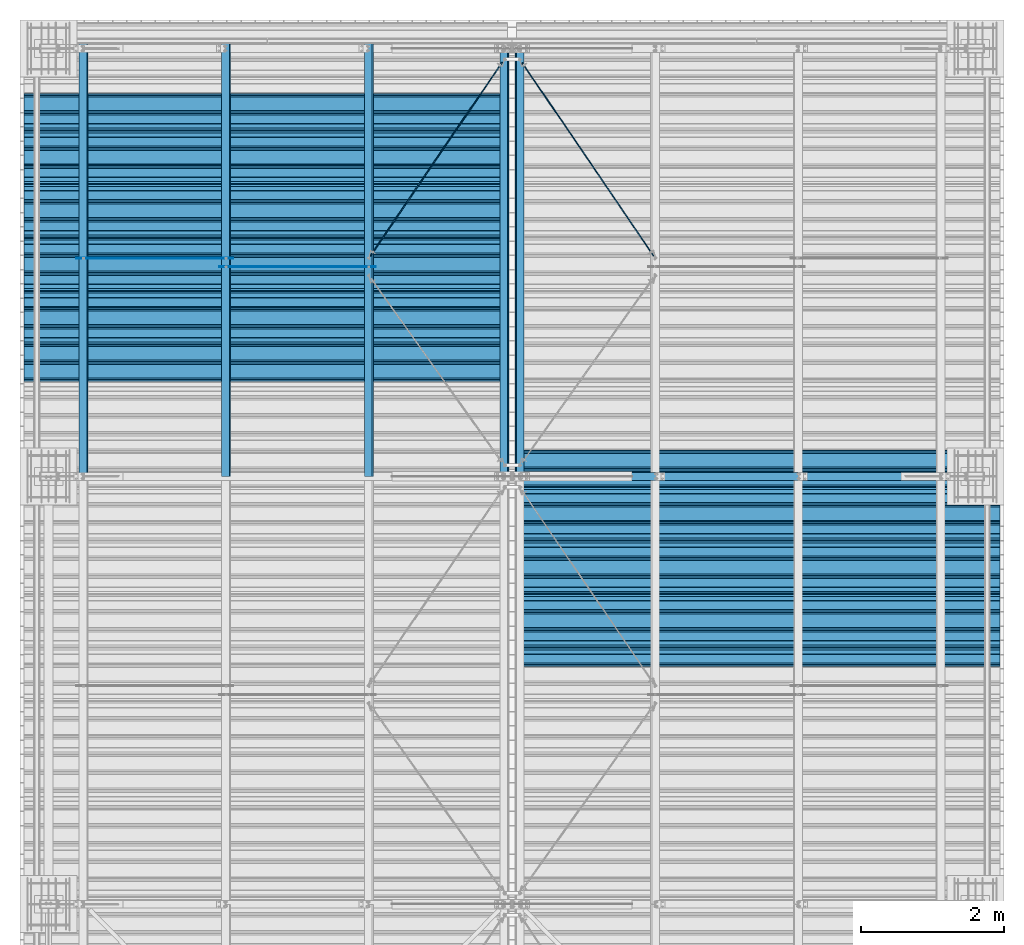
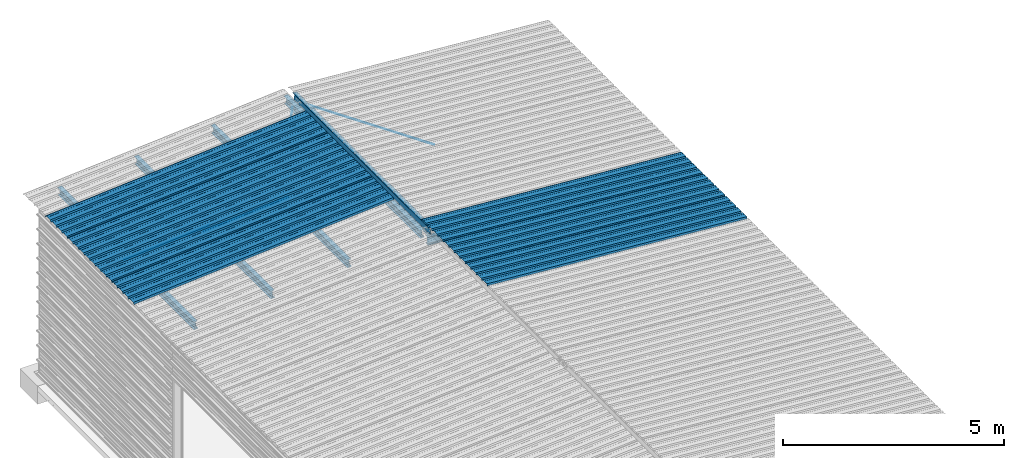
# One storey, part 17 of 70: 17 beams, 17 elements without a shape of their own.
"""IFC2X3 building model written with IfcOpenShell, lengths in millimetres."""

import ifcopenshell
import ifcopenshell.guid

model = None  # the IFC model being written
_history = None  # IfcOwnerHistory: only IFC2X3 demands one
_inside = {}  # id of a spatial element -> (the spatial element, [elements in it])
_under = {}  # id of a project, library or spatial element -> (it, [spatial elements below it])
_declared = {}  # id of a project -> (the project, [libraries it declares])
_typed = {}  # id of a type object -> (the type object, [elements of that type])
_made_of = {}  # id of a material, layer set ... -> (it, [elements and type objects made of it])


def new_model(schema):
    """Start an empty IFC model of exactly this schema.

    Asked for "IFC4X3", IfcOpenShell would pick the latest addendum, in which some entities
    have other attributes; the version numbers below select the first issue.
    IFC2X3 requires an IfcOwnerHistory on every rooted entity: one is made here for all.
    """
    global model, _history
    if schema == "IFC4X3":
        model = ifcopenshell.file(schema_version=(4, 3, 0, 0))
    else:
        model = ifcopenshell.file(schema=schema)
    _inside.clear()
    _under.clear()
    _declared.clear()
    _typed.clear()
    _made_of.clear()
    _history = None
    if model.schema == "IFC2X3":
        org = make("IfcOrganization", Name="unknown")
        user = make(
            "IfcPersonAndOrganization",
            ThePerson=make("IfcPerson", FamilyName="unknown"),
            TheOrganization=org,
        )
        app = make(
            "IfcApplication",
            ApplicationDeveloper=org,
            Version="unknown",
            ApplicationFullName="unknown",
            ApplicationIdentifier="unknown",
        )
        _history = make(
            "IfcOwnerHistory",
            OwningUser=user,
            OwningApplication=app,
            ChangeAction="ADDED",
            CreationDate=0,
        )
    return model


def make(cls, **values):
    """One entity of the class cls with the attributes given. An attribute that is None is left unset."""
    return model.create_entity(
        cls, **{name: value for name, value in values.items() if value is not None}
    )


def rooted(cls, **values):
    """An entity with a GlobalId (a new one), such as an element, a storey or a relation."""
    return make(cls, GlobalId=ifcopenshell.guid.new(), OwnerHistory=_history, **values)


def si_unit(unit_type, name, prefix=None):
    """IfcSIUnit, for example si_unit("LENGTHUNIT", "METRE", prefix="MILLI")."""
    return make("IfcSIUnit", UnitType=unit_type, Prefix=prefix, Name=name)


def assignment(units):
    """IfcUnitAssignment: the units of a project."""
    return None if units is None else make("IfcUnitAssignment", Units=units)


def point(xyz):
    """IfcCartesianPoint."""
    return None if xyz is None else make("IfcCartesianPoint", Coordinates=xyz)


def direction(xyz):
    """IfcDirection."""
    return None if xyz is None else make("IfcDirection", DirectionRatios=xyz)


def frame(location, z_axis=None, x_axis=None):
    """IfcAxis2Placement3D, a coordinate frame: its origin and axes. An axis left out is left unset."""
    return make(
        "IfcAxis2Placement3D",
        Location=point(location),
        Axis=direction(z_axis),
        RefDirection=direction(x_axis),
    )


def frame_2d(location, x_axis=None):
    """IfcAxis2Placement2D, a coordinate frame in the plane: its origin and x axis."""
    return make(
        "IfcAxis2Placement2D", Location=point(location), RefDirection=direction(x_axis)
    )


def origin_with_axes():
    """The frame at (0, 0, 0) with the z axis (0, 0, 1) and the x axis (1, 0, 0) written out."""
    return frame((0.0, 0.0, 0.0), z_axis=(0.0, 0.0, 1.0), x_axis=(1.0, 0.0, 0.0))


def origin_2d_with_axis():
    """The frame at (0, 0) in the plane with the x axis (1, 0) written out."""
    return frame_2d((0.0, 0.0), x_axis=(1.0, 0.0))


def place(relative_to, where):
    """IfcLocalPlacement: puts the frame where relative to a parent placement (None: the world)."""
    return make(
        "IfcLocalPlacement", PlacementRelTo=relative_to, RelativePlacement=where
    )


def context(
    kind, dimensions, precision=None, world=None, true_north=None, identifier=None
):
    """IfcGeometricRepresentationContext, for example the 3D "Model" context."""
    return make(
        "IfcGeometricRepresentationContext",
        ContextIdentifier=identifier,
        ContextType=kind,
        CoordinateSpaceDimension=dimensions,
        Precision=precision,
        WorldCoordinateSystem=world,
        TrueNorth=true_north,
    )


def subcontext(parent, identifier, kind, view, scale=None):
    """IfcGeometricRepresentationSubContext, for example "Body" below "Model"."""
    return make(
        "IfcGeometricRepresentationSubContext",
        ContextIdentifier=identifier,
        ContextType=kind,
        ParentContext=parent,
        TargetScale=scale,
        TargetView=view,
    )


def project(units=None, contexts=None):
    """IfcProject with its units and contexts."""
    return rooted(
        "IfcProject",
        Name="project",
        RepresentationContexts=contexts,
        UnitsInContext=assignment(units),
    )


def spatial(cls, under=None, at=None, **own):
    """A site, building, storey or space (cls), placed at a placement, below another one or the project."""
    s = rooted(cls, ObjectPlacement=at, **own)
    if under is not None:
        _under.setdefault(under.id(), (under, []))[1].append(s)
    return s


def polyline(points):
    """IfcPolyline through the points."""
    return make("IfcPolyline", Points=[point(p) for p in points])


def profile(cls, at=None, kind="AREA", **sizes):
    """A parametric profile (cls). Its sizes go by their IFC names, for example OverallWidth=200.0."""
    return make(cls, ProfileType=kind, Position=at, **sizes)


def circle(**sizes):
    """IfcCircleProfileDef."""
    return profile("IfcCircleProfileDef", **sizes)


def i_section(**sizes):
    """IfcIShapeProfileDef."""
    return profile("IfcIShapeProfileDef", **sizes)


def outline(outer, holes=None, kind="AREA"):
    """IfcArbitraryClosedProfileDef: a profile drawn as a closed curve; with holes, ...WithVoids."""
    if holes is None:
        return make("IfcArbitraryClosedProfileDef", ProfileType=kind, OuterCurve=outer)
    return make(
        "IfcArbitraryProfileDefWithVoids",
        ProfileType=kind,
        OuterCurve=outer,
        InnerCurves=holes,
    )


def extrude(swept, where, along, depth):
    """IfcExtrudedAreaSolid: the profile swept, set in the frame where, extruded along a direction by depth."""
    return make(
        "IfcExtrudedAreaSolid",
        SweptArea=swept,
        Position=where,
        ExtrudedDirection=direction(along),
        Depth=depth,
    )


def clip(a, b, op="DIFFERENCE"):
    """IfcBooleanClippingResult: the solid a cut by the half space b."""
    return make(
        "IfcBooleanClippingResult", Operator=op, FirstOperand=a, SecondOperand=b
    )


def halfspace(plane, agree):
    """IfcHalfSpaceSolid: all space on one side of the plane z = 0 of the frame plane."""
    return make(
        "IfcHalfSpaceSolid",
        BaseSurface=make("IfcPlane", Position=plane),
        AgreementFlag=agree,
    )


def shape(context_of_items, identifier, shape_type, items):
    """IfcShapeRepresentation: the items that make up one representation, for example the "Body"."""
    return make(
        "IfcShapeRepresentation",
        ContextOfItems=context_of_items,
        RepresentationIdentifier=identifier,
        RepresentationType=shape_type,
        Items=items,
    )


def material(Name=None, Category=None):
    """IfcMaterial."""
    return make("IfcMaterial", Name=Name, Category=Category)


def made_of(thing, what):
    """Note that an element or type object is made of a material, layer set ...; save() writes the relation."""
    if what is not None:
        _made_of.setdefault(what.id(), (what, []))[1].append(thing)
    return thing


def type_object(cls, material=None, **own):
    """A type object (cls), such as IfcWallType, which elements share."""
    return made_of(rooted(cls, **own), material)


def element(
    cls,
    number,
    at=None,
    inside=None,
    cuts=None,
    type_object=None,
    material=None,
    context=None,
    identifier="Body",
    shape_type=None,
    held_by="IfcProductDefinitionShape",
    body=None,
    shapes=None,
    **own,
):
    """One element of the class cls, such as IfcWall. Its Tag is "e" and its number.

    at: its placement. inside: the storey or other place that contains it. cuts: it is an
    opening in that element (IfcRelVoidsElement). A single representation is given by context,
    identifier, shape_type and body (its items); several are given by shapes. held_by: the class
    of the entity that holds the representations. save() writes the other relations.
    """
    e = rooted(cls, Tag="e%d" % number, ObjectPlacement=at, **own)
    if body is not None:
        shapes = [shape(context, identifier, shape_type, body)]
    if shapes is not None:
        e.Representation = make(held_by, Representations=shapes)
    if inside is not None:
        _inside.setdefault(inside.id(), (inside, []))[1].append(e)
    if cuts is not None:
        rooted(
            "IfcRelVoidsElement", RelatingBuildingElement=cuts, RelatedOpeningElement=e
        )
    if type_object is not None:
        _typed.setdefault(type_object.id(), (type_object, []))[1].append(e)
    return made_of(e, material)


def aggregate(whole, parts):
    """IfcRelAggregates: a whole, such as a stair, and the parts it consists of."""
    return rooted("IfcRelAggregates", RelatingObject=whole, RelatedObjects=parts)


def save(model, path):
    """Write the relations noted so far, then the file.

    IfcRelAggregates (storeys below a building ...), IfcRelContainedInSpatialStructure (elements
    in a storey), IfcRelDefinesByType, IfcRelAssociatesMaterial and IfcRelDeclares: one each for
    every whole, place, type object, material and project.
    """
    for whole, parts in _under.values():
        aggregate(whole, parts)
    for where, things in _inside.values():
        rooted(
            "IfcRelContainedInSpatialStructure",
            RelatedElements=things,
            RelatingStructure=where,
        )
    for kind, things in _typed.values():
        rooted("IfcRelDefinesByType", RelatedObjects=things, RelatingType=kind)
    for what, things in _made_of.values():
        rooted("IfcRelAssociatesMaterial", RelatedObjects=things, RelatingMaterial=what)
    for by, libraries in _declared.values():
        rooted("IfcRelDeclares", RelatingContext=by, RelatedDefinitions=libraries)
    model.write(path)


model = new_model("IFC2X3")

# Units and contexts
model_context = context("Model", 3, precision=1e-05, world=origin_with_axes())
body_context = subcontext(model_context, "Body", "Model", "MODEL_VIEW")
ifc_project = project(units=[si_unit("LENGTHUNIT", "METRE", prefix="MILLI"), si_unit("AREAUNIT", "SQUARE_METRE"), si_unit("VOLUMEUNIT", "CUBIC_METRE"), si_unit("MASSUNIT", "GRAM", prefix="KILO"), si_unit("TIMEUNIT", "SECOND"), si_unit("PLANEANGLEUNIT", "RADIAN"), si_unit("SOLIDANGLEUNIT", "STERADIAN"), si_unit("THERMODYNAMICTEMPERATUREUNIT", "DEGREE_CELSIUS"), si_unit("LUMINOUSINTENSITYUNIT", "LUMEN")], contexts=[model_context])

# Site, building, storey
site_placement = place(None, origin_with_axes())
site = spatial("IfcSite", under=ifc_project, at=site_placement, CompositionType="ELEMENT")
building_placement = place(site_placement, origin_with_axes())
building = spatial("IfcBuilding", under=site, at=building_placement, Name="Undefined", CompositionType="ELEMENT")
storey_placement = place(building_placement, origin_with_axes())
storey = spatial("IfcBuildingStorey", under=building, at=storey_placement, Name="Undefined", CompositionType="ELEMENT", Elevation=0.0)

# Assembly, beam
assembly_1_placement = place(storey_placement, origin_with_axes())
assembly_1 = element("IfcElementAssembly", 1, at=assembly_1_placement, inside=storey, Name="Steel Assembly", AssemblyPlace="NOTDEFINED", PredefinedType="RIGID_FRAME")
ifc_material = material(Name="STEEL/S235JR")
beam_type_1 = type_object("IfcBeamType", Name="4.40", PredefinedType="NOTDEFINED")
beam_1_placement = place(assembly_1_placement, frame((6563.60751131961, 15850.0000000002, 5336.31760454395), z_axis=(-0.0766964990376782, 0.0, -0.997054485489817), x_axis=(0.997054485489817, 0.0, -0.0766964990376783)))
beam_1 = element("IfcBeam", 2, at=beam_1_placement, type_object=beam_type_1, material=ifc_material, ObjectType="4.40", context=body_context, shape_type="SweptSolid", body=[
    extrude(outline(polyline([(509.415161132813, 19.5000000011705), (490.584838867188, 19.5000000011705), (468.084838867188, -20.4999999988113), (406.585784912109, -20.4999999988113), (404.585784912109, -18.4999999988122), (345.414215087891, -18.4999999988122), (343.414215087891, -20.4999999988113), (281.915161132813, -20.4999999988113), (259.415161132813, 19.5000000011705), (240.584854125977, 19.5000000011705), (218.084854125977, -20.4999999988113), (156.585784912109, -20.4999999988113), (154.585784912109, -18.4999999988122), (95.4142150878906, -18.4999999988122), (93.4142150878906, -20.4999999988113), (31.9151515960693, -20.4999999988113), (9.41515254974365, 19.5000000011705), (-9.41515254974365, 19.5000000011705), (-31.9151515960693, -20.4999999988113), (-93.4142150878906, -20.4999999988113), (-95.4142150878906, -18.4999999988122), (-154.585784912109, -18.4999999988122), (-156.585784912109, -20.4999999988113), (-218.084854125977, -20.4999999988113), (-240.584854125977, 19.5000000011705), (-259.415161132813, 19.5000000011705), (-281.915161132813, -20.4999999988113), (-343.414215087891, -20.4999999988113), (-345.414215087891, -18.4999999988122), (-404.585784912109, -18.4999999988122), (-406.585784912109, -20.4999999988113), (-468.084838867188, -20.4999999988113), (-490.584838867188, 19.5000000011705), (-509.415161132813, 19.5000000011705), (-516.482360839844, 6.9361057293263), (-517.353942871094, 7.42636680720625), (-510.0, 20.5000000011705), (-490.0, 20.5000000011705), (-467.5, -19.4999999988122), (-407.0, -19.4999999988122), (-405.0, -17.4999999988131), (-345.0, -17.4999999988131), (-343.0, -19.4999999988122), (-282.5, -19.4999999988122), (-260.0, 20.5000000011705), (-240.0, 20.5000000011705), (-217.5, -19.4999999988122), (-157.0, -19.4999999988122), (-155.0, -17.4999999988131), (-95.0, -17.4999999988131), (-93.0, -19.4999999988122), (-32.5, -19.4999999988122), (-10.0, 20.5000000011705), (10.0, 20.5000000011705), (32.5, -19.4999999988122), (93.0, -19.4999999988122), (95.0, -17.4999999988131), (155.0, -17.4999999988131), (157.0, -19.4999999988122), (217.5, -19.4999999988122), (240.0, 20.5000000011705), (260.0, 20.5000000011705), (282.5, -19.4999999988122), (343.0, -19.4999999988122), (345.0, -17.4999999988131), (405.0, -17.4999999988131), (407.0, -19.4999999988122), (467.5, -19.4999999988122), (490.0, 20.5000000011705), (510.0, 20.5000000011705), (517.353942871094, 7.42636680720625), (516.482360839844, 6.9361057293263), (509.415161132813, 19.5000000011705)])), frame((6799.99999999733, 2.8421709430404e-14, 0.0), z_axis=(-1.0, 0.0, 0.0), x_axis=(0.0, -1.0, 0.0)), (0.0, 0.0, 1.0), 6800.0),
])
aggregate(assembly_1, [beam_1])

assembly_2_placement = place(storey_placement, origin_with_axes())
assembly_2 = element("IfcElementAssembly", 3, at=assembly_2_placement, inside=storey, Name="Steel Assembly", AssemblyPlace="NOTDEFINED", PredefinedType="RIGID_FRAME")
beam_2_placement = place(assembly_2_placement, frame((6563.60751131961, 16850.0000000002, 5336.31760454398), z_axis=(-0.0766964990376782, 0.0, -0.997054485489817), x_axis=(0.997054485489817, 0.0, -0.0766964990376783)))
beam_2 = element("IfcBeam", 4, at=beam_2_placement, type_object=beam_type_1, material=ifc_material, ObjectType="4.40", context=body_context, shape_type="SweptSolid", body=[
    extrude(outline(polyline([(509.415161132813, 19.5000000011705), (490.584838867188, 19.5000000011705), (468.084838867188, -20.4999999988113), (406.585784912109, -20.4999999988113), (404.585784912109, -18.4999999988122), (345.414215087891, -18.4999999988122), (343.414215087891, -20.4999999988113), (281.915161132813, -20.4999999988113), (259.415161132813, 19.5000000011705), (240.584854125977, 19.5000000011705), (218.084854125977, -20.4999999988113), (156.585784912109, -20.4999999988113), (154.585784912109, -18.4999999988122), (95.4142150878906, -18.4999999988122), (93.4142150878906, -20.4999999988113), (31.9151515960693, -20.4999999988113), (9.41515254974365, 19.5000000011705), (-9.41515254974365, 19.5000000011705), (-31.9151515960693, -20.4999999988113), (-93.4142150878906, -20.4999999988113), (-95.4142150878906, -18.4999999988122), (-154.585784912109, -18.4999999988122), (-156.585784912109, -20.4999999988113), (-218.084854125977, -20.4999999988113), (-240.584854125977, 19.5000000011705), (-259.415161132813, 19.5000000011705), (-281.915161132813, -20.4999999988113), (-343.414215087891, -20.4999999988113), (-345.414215087891, -18.4999999988122), (-404.585784912109, -18.4999999988122), (-406.585784912109, -20.4999999988113), (-468.084838867188, -20.4999999988113), (-490.584838867188, 19.5000000011705), (-509.415161132813, 19.5000000011705), (-516.482360839844, 6.9361057293263), (-517.353942871094, 7.42636680720625), (-510.0, 20.5000000011705), (-490.0, 20.5000000011705), (-467.5, -19.4999999988122), (-407.0, -19.4999999988122), (-405.0, -17.4999999988131), (-345.0, -17.4999999988131), (-343.0, -19.4999999988122), (-282.5, -19.4999999988122), (-260.0, 20.5000000011705), (-240.0, 20.5000000011705), (-217.5, -19.4999999988122), (-157.0, -19.4999999988122), (-155.0, -17.4999999988131), (-95.0, -17.4999999988131), (-93.0, -19.4999999988122), (-32.5, -19.4999999988122), (-10.0, 20.5000000011705), (10.0, 20.5000000011705), (32.5, -19.4999999988122), (93.0, -19.4999999988122), (95.0, -17.4999999988131), (155.0, -17.4999999988131), (157.0, -19.4999999988122), (217.5, -19.4999999988122), (240.0, 20.5000000011705), (260.0, 20.5000000011705), (282.5, -19.4999999988122), (343.0, -19.4999999988122), (345.0, -17.4999999988131), (405.0, -17.4999999988131), (407.0, -19.4999999988122), (467.5, -19.4999999988122), (490.0, 20.5000000011705), (510.0, 20.5000000011705), (517.353942871094, 7.42636680720625), (516.482360839844, 6.9361057293263), (509.415161132813, 19.5000000011705)])), frame((6799.99999999733, 2.8421709430404e-14, 0.0), z_axis=(-1.0, 0.0, 0.0), x_axis=(0.0, -1.0, 0.0)), (0.0, 0.0, 1.0), 6800.0),
])
aggregate(assembly_2, [beam_2])

assembly_3_placement = place(storey_placement, origin_with_axes())
assembly_3 = element("IfcElementAssembly", 5, at=assembly_3_placement, inside=storey, Name="Steel Assembly", AssemblyPlace="NOTDEFINED", PredefinedType="RIGID_FRAME")
beam_3_placement = place(assembly_3_placement, frame((6563.60751131961, 17850.0000000002, 5336.31760454401), z_axis=(-0.0766964990376782, 0.0, -0.997054485489817), x_axis=(0.997054485489817, 0.0, -0.0766964990376783)))
beam_3 = element("IfcBeam", 6, at=beam_3_placement, type_object=beam_type_1, material=ifc_material, ObjectType="4.40", context=body_context, shape_type="SweptSolid", body=[
    extrude(outline(polyline([(509.415161132813, 19.5000000011705), (490.584838867188, 19.5000000011705), (468.084838867188, -20.4999999988113), (406.585784912109, -20.4999999988113), (404.585784912109, -18.4999999988122), (345.414215087891, -18.4999999988122), (343.414215087891, -20.4999999988113), (281.915161132813, -20.4999999988113), (259.415161132813, 19.5000000011705), (240.584854125977, 19.5000000011705), (218.084854125977, -20.4999999988113), (156.585784912109, -20.4999999988113), (154.585784912109, -18.4999999988122), (95.4142150878906, -18.4999999988122), (93.4142150878906, -20.4999999988113), (31.9151515960693, -20.4999999988113), (9.41515254974365, 19.5000000011705), (-9.41515254974365, 19.5000000011705), (-31.9151515960693, -20.4999999988113), (-93.4142150878906, -20.4999999988113), (-95.4142150878906, -18.4999999988122), (-154.585784912109, -18.4999999988122), (-156.585784912109, -20.4999999988113), (-218.084854125977, -20.4999999988113), (-240.584854125977, 19.5000000011705), (-259.415161132813, 19.5000000011705), (-281.915161132813, -20.4999999988113), (-343.414215087891, -20.4999999988113), (-345.414215087891, -18.4999999988122), (-404.585784912109, -18.4999999988122), (-406.585784912109, -20.4999999988113), (-468.084838867188, -20.4999999988113), (-490.584838867188, 19.5000000011705), (-509.415161132813, 19.5000000011705), (-516.482360839844, 6.9361057293263), (-517.353942871094, 7.42636680720625), (-510.0, 20.5000000011705), (-490.0, 20.5000000011705), (-467.5, -19.4999999988122), (-407.0, -19.4999999988122), (-405.0, -17.4999999988131), (-345.0, -17.4999999988131), (-343.0, -19.4999999988122), (-282.5, -19.4999999988122), (-260.0, 20.5000000011705), (-240.0, 20.5000000011705), (-217.5, -19.4999999988122), (-157.0, -19.4999999988122), (-155.0, -17.4999999988131), (-95.0, -17.4999999988131), (-93.0, -19.4999999988122), (-32.5, -19.4999999988122), (-10.0, 20.5000000011705), (10.0, 20.5000000011705), (32.5, -19.4999999988122), (93.0, -19.4999999988122), (95.0, -17.4999999988131), (155.0, -17.4999999988131), (157.0, -19.4999999988122), (217.5, -19.4999999988122), (240.0, 20.5000000011705), (260.0, 20.5000000011705), (282.5, -19.4999999988122), (343.0, -19.4999999988122), (345.0, -17.4999999988131), (405.0, -17.4999999988131), (407.0, -19.4999999988122), (467.5, -19.4999999988122), (490.0, 20.5000000011705), (510.0, 20.5000000011705), (517.353942871094, 7.42636680720625), (516.482360839844, 6.9361057293263), (509.415161132813, 19.5000000011705)])), frame((6799.99999999733, 2.8421709430404e-14, 0.0), z_axis=(-1.0, 0.0, 0.0), x_axis=(0.0, -1.0, 0.0)), (0.0, 0.0, 1.0), 6800.0),
])
aggregate(assembly_3, [beam_3])

assembly_4_placement = place(storey_placement, origin_with_axes())
assembly_4 = element("IfcElementAssembly", 7, at=assembly_4_placement, inside=storey, Name="Steel Assembly", AssemblyPlace="NOTDEFINED", PredefinedType="RIGID_FRAME")
beam_4_placement = place(assembly_4_placement, frame((6436.39248868039, 19850.0, 5336.31760454388), z_axis=(0.0766964990376782, 0.0, -0.997054485489817), x_axis=(-0.997054485489818, 0.0, -0.0766964990376602)))
beam_4 = element("IfcBeam", 8, at=beam_4_placement, type_object=beam_type_1, material=ifc_material, ObjectType="4.40", context=body_context, shape_type="SweptSolid", body=[
    extrude(outline(polyline([(509.415161132813, 19.5000000011705), (490.584838867188, 19.5000000011705), (468.084838867188, -20.4999999988113), (406.585784912109, -20.4999999988113), (404.585784912109, -18.4999999988122), (345.414215087891, -18.4999999988122), (343.414215087891, -20.4999999988113), (281.915161132813, -20.4999999988113), (259.415161132813, 19.5000000011705), (240.584854125977, 19.5000000011705), (218.084854125977, -20.4999999988113), (156.585784912109, -20.4999999988113), (154.585784912109, -18.4999999988122), (95.4142150878906, -18.4999999988122), (93.4142150878906, -20.4999999988113), (31.9151515960693, -20.4999999988113), (9.41515254974365, 19.5000000011705), (-9.41515254974365, 19.5000000011705), (-31.9151515960693, -20.4999999988113), (-93.4142150878906, -20.4999999988113), (-95.4142150878906, -18.4999999988122), (-154.585784912109, -18.4999999988122), (-156.585784912109, -20.4999999988113), (-218.084854125977, -20.4999999988113), (-240.584854125977, 19.5000000011705), (-259.415161132813, 19.5000000011705), (-281.915161132813, -20.4999999988113), (-343.414215087891, -20.4999999988113), (-345.414215087891, -18.4999999988122), (-404.585784912109, -18.4999999988122), (-406.585784912109, -20.4999999988113), (-468.084838867188, -20.4999999988113), (-490.584838867188, 19.5000000011705), (-509.415161132813, 19.5000000011705), (-516.482360839844, 6.9361057293263), (-517.353942871094, 7.42636680720625), (-510.0, 20.5000000011705), (-490.0, 20.5000000011705), (-467.5, -19.4999999988122), (-407.0, -19.4999999988122), (-405.0, -17.4999999988131), (-345.0, -17.4999999988131), (-343.0, -19.4999999988122), (-282.5, -19.4999999988122), (-260.0, 20.5000000011705), (-240.0, 20.5000000011705), (-217.5, -19.4999999988122), (-157.0, -19.4999999988122), (-155.0, -17.4999999988131), (-95.0, -17.4999999988131), (-93.0, -19.4999999988122), (-32.5, -19.4999999988122), (-10.0, 20.5000000011705), (10.0, 20.5000000011705), (32.5, -19.4999999988122), (93.0, -19.4999999988122), (95.0, -17.4999999988131), (155.0, -17.4999999988131), (157.0, -19.4999999988122), (217.5, -19.4999999988122), (240.0, 20.5000000011705), (260.0, 20.5000000011705), (282.5, -19.4999999988122), (343.0, -19.4999999988122), (345.0, -17.4999999988131), (405.0, -17.4999999988131), (407.0, -19.4999999988122), (467.5, -19.4999999988122), (490.0, 20.5000000011705), (510.0, 20.5000000011705), (517.353942871094, 7.42636680720625), (516.482360839844, 6.9361057293263), (509.415161132813, 19.5000000011705)])), frame((6799.99999999733, 2.8421709430404e-14, 0.0), z_axis=(-1.0, 0.0, 0.0), x_axis=(0.0, -1.0, 0.0)), (0.0, 0.0, 1.0), 6800.0),
])
aggregate(assembly_4, [beam_4])

assembly_5_placement = place(storey_placement, origin_with_axes())
assembly_5 = element("IfcElementAssembly", 9, at=assembly_5_placement, inside=storey, Name="Steel Assembly", AssemblyPlace="NOTDEFINED", PredefinedType="RIGID_FRAME")
beam_5_placement = place(assembly_5_placement, frame((6436.39248868039, 20850.0, 5336.31760454388), z_axis=(0.0766964990376782, 0.0, -0.997054485489817), x_axis=(-0.997054485489818, 0.0, -0.0766964990376602)))
beam_5 = element("IfcBeam", 10, at=beam_5_placement, type_object=beam_type_1, material=ifc_material, ObjectType="4.40", context=body_context, shape_type="SweptSolid", body=[
    extrude(outline(polyline([(509.415161132813, 19.5000000011705), (490.584838867188, 19.5000000011705), (468.084838867188, -20.4999999988113), (406.585784912109, -20.4999999988113), (404.585784912109, -18.4999999988122), (345.414215087891, -18.4999999988122), (343.414215087891, -20.4999999988113), (281.915161132813, -20.4999999988113), (259.415161132813, 19.5000000011705), (240.584854125977, 19.5000000011705), (218.084854125977, -20.4999999988113), (156.585784912109, -20.4999999988113), (154.585784912109, -18.4999999988122), (95.4142150878906, -18.4999999988122), (93.4142150878906, -20.4999999988113), (31.9151515960693, -20.4999999988113), (9.41515254974365, 19.5000000011705), (-9.41515254974365, 19.5000000011705), (-31.9151515960693, -20.4999999988113), (-93.4142150878906, -20.4999999988113), (-95.4142150878906, -18.4999999988122), (-154.585784912109, -18.4999999988122), (-156.585784912109, -20.4999999988113), (-218.084854125977, -20.4999999988113), (-240.584854125977, 19.5000000011705), (-259.415161132813, 19.5000000011705), (-281.915161132813, -20.4999999988113), (-343.414215087891, -20.4999999988113), (-345.414215087891, -18.4999999988122), (-404.585784912109, -18.4999999988122), (-406.585784912109, -20.4999999988113), (-468.084838867188, -20.4999999988113), (-490.584838867188, 19.5000000011705), (-509.415161132813, 19.5000000011705), (-516.482360839844, 6.9361057293263), (-517.353942871094, 7.42636680720625), (-510.0, 20.5000000011705), (-490.0, 20.5000000011705), (-467.5, -19.4999999988122), (-407.0, -19.4999999988122), (-405.0, -17.4999999988131), (-345.0, -17.4999999988131), (-343.0, -19.4999999988122), (-282.5, -19.4999999988122), (-260.0, 20.5000000011705), (-240.0, 20.5000000011705), (-217.5, -19.4999999988122), (-157.0, -19.4999999988122), (-155.0, -17.4999999988131), (-95.0, -17.4999999988131), (-93.0, -19.4999999988122), (-32.5, -19.4999999988122), (-10.0, 20.5000000011705), (10.0, 20.5000000011705), (32.5, -19.4999999988122), (93.0, -19.4999999988122), (95.0, -17.4999999988131), (155.0, -17.4999999988131), (157.0, -19.4999999988122), (217.5, -19.4999999988122), (240.0, 20.5000000011705), (260.0, 20.5000000011705), (282.5, -19.4999999988122), (343.0, -19.4999999988122), (345.0, -17.4999999988131), (405.0, -17.4999999988131), (407.0, -19.4999999988122), (467.5, -19.4999999988122), (490.0, 20.5000000011705), (510.0, 20.5000000011705), (517.353942871094, 7.42636680720625), (516.482360839844, 6.9361057293263), (509.415161132813, 19.5000000011705)])), frame((6799.99999999733, 2.8421709430404e-14, 0.0), z_axis=(-1.0, 0.0, 0.0), x_axis=(0.0, -1.0, 0.0)), (0.0, 0.0, 1.0), 6800.0),
])
aggregate(assembly_5, [beam_5])

assembly_6_placement = place(storey_placement, origin_with_axes())
assembly_6 = element("IfcElementAssembly", 11, at=assembly_6_placement, inside=storey, Name="Steel Assembly", AssemblyPlace="NOTDEFINED", PredefinedType="RIGID_FRAME")
beam_6_placement = place(assembly_6_placement, frame((6436.39248868039, 21850.0, 5336.31760454388), z_axis=(0.0766964990376782, 0.0, -0.997054485489817), x_axis=(-0.997054485489818, 0.0, -0.0766964990376602)))
beam_6 = element("IfcBeam", 12, at=beam_6_placement, type_object=beam_type_1, material=ifc_material, ObjectType="4.40", context=body_context, shape_type="SweptSolid", body=[
    extrude(outline(polyline([(509.415161132813, 19.5000000011705), (490.584838867188, 19.5000000011705), (468.084838867188, -20.4999999988113), (406.585784912109, -20.4999999988113), (404.585784912109, -18.4999999988122), (345.414215087891, -18.4999999988122), (343.414215087891, -20.4999999988113), (281.915161132813, -20.4999999988113), (259.415161132813, 19.5000000011705), (240.584854125977, 19.5000000011705), (218.084854125977, -20.4999999988113), (156.585784912109, -20.4999999988113), (154.585784912109, -18.4999999988122), (95.4142150878906, -18.4999999988122), (93.4142150878906, -20.4999999988113), (31.9151515960693, -20.4999999988113), (9.41515254974365, 19.5000000011705), (-9.41515254974365, 19.5000000011705), (-31.9151515960693, -20.4999999988113), (-93.4142150878906, -20.4999999988113), (-95.4142150878906, -18.4999999988122), (-154.585784912109, -18.4999999988122), (-156.585784912109, -20.4999999988113), (-218.084854125977, -20.4999999988113), (-240.584854125977, 19.5000000011705), (-259.415161132813, 19.5000000011705), (-281.915161132813, -20.4999999988113), (-343.414215087891, -20.4999999988113), (-345.414215087891, -18.4999999988122), (-404.585784912109, -18.4999999988122), (-406.585784912109, -20.4999999988113), (-468.084838867188, -20.4999999988113), (-490.584838867188, 19.5000000011705), (-509.415161132813, 19.5000000011705), (-516.482360839844, 6.9361057293263), (-517.353942871094, 7.42636680720625), (-510.0, 20.5000000011705), (-490.0, 20.5000000011705), (-467.5, -19.4999999988122), (-407.0, -19.4999999988122), (-405.0, -17.4999999988131), (-345.0, -17.4999999988131), (-343.0, -19.4999999988122), (-282.5, -19.4999999988122), (-260.0, 20.5000000011705), (-240.0, 20.5000000011705), (-217.5, -19.4999999988122), (-157.0, -19.4999999988122), (-155.0, -17.4999999988131), (-95.0, -17.4999999988131), (-93.0, -19.4999999988122), (-32.5, -19.4999999988122), (-10.0, 20.5000000011705), (10.0, 20.5000000011705), (32.5, -19.4999999988122), (93.0, -19.4999999988122), (95.0, -17.4999999988131), (155.0, -17.4999999988131), (157.0, -19.4999999988122), (217.5, -19.4999999988122), (240.0, 20.5000000011705), (260.0, 20.5000000011705), (282.5, -19.4999999988122), (343.0, -19.4999999988122), (345.0, -17.4999999988131), (405.0, -17.4999999988131), (407.0, -19.4999999988122), (467.5, -19.4999999988122), (490.0, 20.5000000011705), (510.0, 20.5000000011705), (517.353942871094, 7.42636680720625), (516.482360839844, 6.9361057293263), (509.415161132813, 19.5000000011705)])), frame((6799.99999999733, 2.8421709430404e-14, 0.0), z_axis=(-1.0, 0.0, 0.0), x_axis=(0.0, -1.0, 0.0)), (0.0, 0.0, 1.0), 6800.0),
])
aggregate(assembly_6, [beam_6])

assembly_7_placement = place(storey_placement, origin_with_axes())
assembly_7 = element("IfcElementAssembly", 13, at=assembly_7_placement, inside=storey, Name="Steel Assembly", AssemblyPlace="NOTDEFINED", PredefinedType="RIGID_FRAME")
beam_7_placement = place(assembly_7_placement, frame((6436.39248868039, 22850.0, 5336.31760454388), z_axis=(0.0766964990376782, 0.0, -0.997054485489817), x_axis=(-0.997054485489818, 0.0, -0.0766964990376602)))
beam_7 = element("IfcBeam", 14, at=beam_7_placement, type_object=beam_type_1, material=ifc_material, ObjectType="4.40", context=body_context, shape_type="SweptSolid", body=[
    extrude(outline(polyline([(509.415161132813, 19.5000000011705), (490.584838867188, 19.5000000011705), (468.084838867188, -20.4999999988113), (406.585784912109, -20.4999999988113), (404.585784912109, -18.4999999988122), (345.414215087891, -18.4999999988122), (343.414215087891, -20.4999999988113), (281.915161132813, -20.4999999988113), (259.415161132813, 19.5000000011705), (240.584854125977, 19.5000000011705), (218.084854125977, -20.4999999988113), (156.585784912109, -20.4999999988113), (154.585784912109, -18.4999999988122), (95.4142150878906, -18.4999999988122), (93.4142150878906, -20.4999999988113), (31.9151515960693, -20.4999999988113), (9.41515254974365, 19.5000000011705), (-9.41515254974365, 19.5000000011705), (-31.9151515960693, -20.4999999988113), (-93.4142150878906, -20.4999999988113), (-95.4142150878906, -18.4999999988122), (-154.585784912109, -18.4999999988122), (-156.585784912109, -20.4999999988113), (-218.084854125977, -20.4999999988113), (-240.584854125977, 19.5000000011705), (-259.415161132813, 19.5000000011705), (-281.915161132813, -20.4999999988113), (-343.414215087891, -20.4999999988113), (-345.414215087891, -18.4999999988122), (-404.585784912109, -18.4999999988122), (-406.585784912109, -20.4999999988113), (-468.084838867188, -20.4999999988113), (-490.584838867188, 19.5000000011705), (-509.415161132813, 19.5000000011705), (-516.482360839844, 6.9361057293263), (-517.353942871094, 7.42636680720625), (-510.0, 20.5000000011705), (-490.0, 20.5000000011705), (-467.5, -19.4999999988122), (-407.0, -19.4999999988122), (-405.0, -17.4999999988131), (-345.0, -17.4999999988131), (-343.0, -19.4999999988122), (-282.5, -19.4999999988122), (-260.0, 20.5000000011705), (-240.0, 20.5000000011705), (-217.5, -19.4999999988122), (-157.0, -19.4999999988122), (-155.0, -17.4999999988131), (-95.0, -17.4999999988131), (-93.0, -19.4999999988122), (-32.5, -19.4999999988122), (-10.0, 20.5000000011705), (10.0, 20.5000000011705), (32.5, -19.4999999988122), (93.0, -19.4999999988122), (95.0, -17.4999999988131), (155.0, -17.4999999988131), (157.0, -19.4999999988122), (217.5, -19.4999999988122), (240.0, 20.5000000011705), (260.0, 20.5000000011705), (282.5, -19.4999999988122), (343.0, -19.4999999988122), (345.0, -17.4999999988131), (405.0, -17.4999999988131), (407.0, -19.4999999988122), (467.5, -19.4999999988122), (490.0, 20.5000000011705), (510.0, 20.5000000011705), (517.353942871094, 7.42636680720625), (516.482360839844, 6.9361057293263), (509.415161132813, 19.5000000011705)])), frame((6799.99999999733, 2.8421709430404e-14, 0.0), z_axis=(-1.0, 0.0, 0.0), x_axis=(0.0, -1.0, 0.0)), (0.0, 0.0, 1.0), 6800.0),
])
aggregate(assembly_7, [beam_7])

assembly_8_placement = place(storey_placement, origin_with_axes())
assembly_8 = element("IfcElementAssembly", 15, at=assembly_8_placement, inside=storey, Name="Steel Assembly", AssemblyPlace="NOTDEFINED", PredefinedType="RIGID_FRAME")
beam_type_2 = type_object("IfcBeamType", Name="D14", PredefinedType="NOTDEFINED")
beam_8_placement = place(assembly_8_placement, frame((6643.29022095678, 23798.8202310421, 5199.30263958542), z_axis=(-0.0766964990376782, 0.0, -0.997054485489817), x_axis=(0.562350226933823, -0.825766911902794, -0.0432577099948882)))
beam_8 = element("IfcBeam", 16, at=beam_8_placement, type_object=beam_type_2, material=ifc_material, Name="THREAD60MM", ObjectType="D14", context=body_context, shape_type="SweptSolid", body=[
    extrude(circle(Radius=7.0, at=origin_2d_with_axis()), frame((3276.46854148328, -3.44046790741365e-12, -2.27350675888422e-14), z_axis=(-1.0, 0.0, 0.0), x_axis=(0.0, -1.0, 0.0)), (0.0, 0.0, 1.0), 3276.47),
])
aggregate(assembly_8, [beam_8])

assembly_9_placement = place(storey_placement, origin_with_axes())
assembly_9 = element("IfcElementAssembly", 17, at=assembly_9_placement, inside=storey, Name="Steel Assembly", AssemblyPlace="NOTDEFINED", PredefinedType="RIGID_FRAME")
beam_9_placement = place(assembly_9_placement, frame((6360.89585869421, 23804.9671585294, 5199.62464571418), z_axis=(0.0766964990376782, 0.0, -0.997054485489817), x_axis=(-0.5623502269338, -0.825766911902807, -0.0432577099949295)))
beam_9 = element("IfcBeam", 18, at=beam_9_placement, type_object=beam_type_2, material=ifc_material, Name="THREAD60MM", ObjectType="D14", context=body_context, shape_type="SweptSolid", body=[
    extrude(circle(Radius=7.0, at=origin_2d_with_axis()), frame((3283.91244290157, 3.26911877658966e-12, -9.09494701772928e-13), z_axis=(-1.0, 0.0, 0.0), x_axis=(0.0, -1.0, 0.0)), (0.0, 0.0, 1.0), 3283.91),
])
aggregate(assembly_9, [beam_9])

assembly_10_placement = place(storey_placement, origin_with_axes())
assembly_10 = element("IfcElementAssembly", 19, at=assembly_10_placement, inside=storey, Name="Steel Assembly", AssemblyPlace="NOTDEFINED", PredefinedType="RIGID_FRAME")
beam_10_placement = place(assembly_10_placement, frame((2591.26883365322, 21060.0000000001, 4909.65333500212), z_axis=(0.0766964990376782, 0.0, -0.997054485489817), x_axis=(-0.997054485489818, 0.0, -0.0766964990376602)))
beam_10 = element("IfcBeam", 20, at=beam_10_placement, type_object=beam_type_2, material=ifc_material, Name="THREAD60MM", ObjectType="D14", context=body_context, shape_type="SweptSolid", body=[
    extrude(circle(Radius=7.0, at=origin_2d_with_axis()), frame((2205.90843239298, 9.09494701772928e-13, -9.40107830921147e-13), z_axis=(-1.0, 0.0, 0.0), x_axis=(0.0, -1.0, 0.0)), (0.0, 0.0, 1.0), 2205.91),
])
aggregate(assembly_10, [beam_10])

assembly_11_placement = place(storey_placement, origin_with_axes())
assembly_11 = element("IfcElementAssembly", 21, at=assembly_11_placement, inside=storey, Name="Steel Assembly", AssemblyPlace="NOTDEFINED", PredefinedType="RIGID_FRAME")
beam_11_placement = place(assembly_11_placement, frame((4591.26883365324, 20940.0000000001, 5063.49948915789), z_axis=(0.0766964990376782, 0.0, -0.997054485489817), x_axis=(-0.997054485489818, 0.0, -0.0766964990376602)))
beam_11 = element("IfcBeam", 22, at=beam_11_placement, type_object=beam_type_2, material=ifc_material, Name="THREAD60MM", ObjectType="D14", context=body_context, shape_type="SweptSolid", body=[
    extrude(circle(Radius=7.0, at=origin_2d_with_axis()), frame((2205.90843239298, 9.09494701772928e-13, -9.40107830921147e-13), z_axis=(-1.0, 0.0, 0.0), x_axis=(0.0, -1.0, 0.0)), (0.0, 0.0, 1.0), 2205.91),
])
aggregate(assembly_11, [beam_11])

assembly_12_placement = place(storey_placement, origin_with_axes())
assembly_12 = element("IfcElementAssembly", 23, at=assembly_12_placement, inside=storey, Name="Steel Assembly", AssemblyPlace="NOTDEFINED", PredefinedType="RIGID_FRAME")
beam_type_3 = type_object("IfcBeamType", Name="IPE220", PredefinedType="NOTDEFINED")
beam_12_placement = place(assembly_12_placement, frame((6608.43661485526, 18000.0, 5201.98368622298), z_axis=(0.0766964990376782, 0.0, 0.997054485489817), x_axis=(0.0, 1.0, 0.0)))
beam_12 = element("IfcBeam", 24, at=beam_12_placement, type_object=beam_type_3, material=ifc_material, ObjectType="IPE220", context=body_context, shape_type="Clipping", body=[
    clip(extrude(i_section(OverallWidth=110.0, OverallDepth=220.0, WebThickness=5.900000095, FlangeThickness=9.199999809, FilletRadius=12.0, at=origin_2d_with_axis()), frame((6150.0000000001, 0.0, 0.0), z_axis=(-1.0, 0.0, 0.0), x_axis=(0.0, -1.0, 0.0)), (0.0, 0.0, 1.0), 6145.0), halfspace(frame((4.99999999999636, 7.09405867382884e-11, -1.79170456249267e-10), z_axis=(1.0, 0.0, 0.0), x_axis=(0.0, -1.0, 0.0)), True)),
])
aggregate(assembly_12, [beam_12])

assembly_13_placement = place(storey_placement, origin_with_axes())
assembly_13 = element("IfcElementAssembly", 25, at=assembly_13_placement, inside=storey, Name="Steel Assembly", AssemblyPlace="NOTDEFINED", PredefinedType="RIGID_FRAME")
beam_13_placement = place(assembly_13_placement, frame((6391.56338514147, 24149.9999999999, 5201.98368623921), z_axis=(-0.0766964990376602, 0.0, 0.997054485489818), x_axis=(0.0, -1.0, 0.0)))
beam_13 = element("IfcBeam", 26, at=beam_13_placement, type_object=beam_type_3, material=ifc_material, ObjectType="IPE220", context=body_context, shape_type="Clipping", body=[
    clip(extrude(i_section(OverallWidth=110.0, OverallDepth=220.0, WebThickness=5.900000095, FlangeThickness=9.199999809, FilletRadius=12.0, at=origin_2d_with_axis()), frame((6144.99999999991, 0.0, 0.0), z_axis=(-1.0, 0.0, 0.0), x_axis=(0.0, -1.0, 0.0)), (0.0, 0.0, 1.0), 6145.0), halfspace(frame((6144.99999999991, 0.0, 0.0), z_axis=(1.0, 0.0, 0.0), x_axis=(0.0, -1.0, 0.0)), False)),
])
aggregate(assembly_13, [beam_13])

assembly_14_placement = place(storey_placement, origin_with_axes())
assembly_14 = element("IfcElementAssembly", 27, at=assembly_14_placement, inside=storey, Name="Steel Assembly", AssemblyPlace="NOTDEFINED", PredefinedType="RIGID_FRAME")
beam_14_placement = place(assembly_14_placement, frame((4491.56338512999, 24149.9999999999, 5055.82983993555), z_axis=(-0.0766964990376602, 0.0, 0.997054485489818), x_axis=(0.0, -1.0, 0.0)))
beam_14 = element("IfcBeam", 28, at=beam_14_placement, type_object=beam_type_3, material=ifc_material, ObjectType="IPE220", context=body_context, shape_type="SweptSolid", body=[
    extrude(i_section(OverallWidth=110.0, OverallDepth=220.0, WebThickness=5.900000095, FlangeThickness=9.199999809, FilletRadius=12.0, at=origin_2d_with_axis()), frame((6150.0000000001, 0.0, 0.0), z_axis=(-1.0, 0.0, 0.0), x_axis=(0.0, -1.0, 0.0)), (0.0, 0.0, 1.0), 6150.0),
])
aggregate(assembly_14, [beam_14])

assembly_15_placement = place(storey_placement, origin_with_axes())
assembly_15 = element("IfcElementAssembly", 29, at=assembly_15_placement, inside=storey, Name="Steel Assembly", AssemblyPlace="NOTDEFINED", PredefinedType="RIGID_FRAME")
beam_15_placement = place(assembly_15_placement, frame((2491.5633851179, 24149.9999999999, 4901.9836859317), z_axis=(-0.0766964990376602, 0.0, 0.997054485489818), x_axis=(0.0, -1.0, 0.0)))
beam_15 = element("IfcBeam", 30, at=beam_15_placement, type_object=beam_type_3, material=ifc_material, ObjectType="IPE220", context=body_context, shape_type="SweptSolid", body=[
    extrude(i_section(OverallWidth=110.0, OverallDepth=220.0, WebThickness=5.900000095, FlangeThickness=9.199999809, FilletRadius=12.0, at=origin_2d_with_axis()), frame((6150.0000000001, 0.0, 0.0), z_axis=(-1.0, 0.0, 0.0), x_axis=(0.0, -1.0, 0.0)), (0.0, 0.0, 1.0), 6150.0),
])
aggregate(assembly_15, [beam_15])

assembly_16_placement = place(storey_placement, origin_with_axes())
assembly_16 = element("IfcElementAssembly", 31, at=assembly_16_placement, inside=storey, Name="Steel Assembly", AssemblyPlace="NOTDEFINED", PredefinedType="RIGID_FRAME")
beam_16_placement = place(assembly_16_placement, frame((491.563385106019, 24149.9999999999, 4748.1375319274), z_axis=(-0.0766964990376602, 0.0, 0.997054485489818), x_axis=(0.0, -1.0, 0.0)))
beam_16 = element("IfcBeam", 32, at=beam_16_placement, type_object=beam_type_3, material=ifc_material, ObjectType="IPE220", context=body_context, shape_type="Clipping", body=[
    clip(extrude(i_section(OverallWidth=110.0, OverallDepth=220.0, WebThickness=5.900000095, FlangeThickness=9.199999809, FilletRadius=12.0, at=origin_2d_with_axis()), frame((6144.99999999991, 0.0, 0.0), z_axis=(-1.0, 0.0, 0.0), x_axis=(0.0, -1.0, 0.0)), (0.0, 0.0, 1.0), 6145.0), halfspace(frame((6144.99999999991, 0.0, 0.0), z_axis=(1.0, 0.0, 0.0), x_axis=(0.0, -1.0, 0.0)), False)),
])
aggregate(assembly_16, [beam_16])

assembly_17_placement = place(storey_placement, origin_with_axes())
assembly_17 = element("IfcElementAssembly", 33, at=assembly_17_placement, inside=storey, Name="Steel Assembly", AssemblyPlace="NOTDEFINED", PredefinedType="RIGID_FRAME")
beam_17_placement = place(assembly_17_placement, frame((6491.56338512267, 18000.0, 4990.32400659478), z_axis=(0.0766964990376782, 0.0, 0.997054485489817), x_axis=(0.997054485489817, 0.0, -0.0766964990376783)))
beam_17 = element("IfcBeam", 34, at=beam_17_placement, type_object=beam_type_3, material=ifc_material, Name="POUTRE", ObjectType="IPE220", context=body_context, shape_type="Clipping", body=[
    clip(clip(extrude(i_section(OverallWidth=110.0, OverallDepth=220.0, WebThickness=5.900000095, FlangeThickness=9.199999809, FilletRadius=12.0, at=origin_2d_with_axis()), frame((6409.35743228136, 3.63797880709171e-12, 8.89477024296393e-14), z_axis=(-1.0, 0.0, 0.0), x_axis=(0.0, -1.0, 0.0)), (0.0, 0.0, 1.0), 6402.94), halfspace(frame((6400.72666295692, 3.63797880709171e-12, -109.999999009079), z_axis=(-0.997054485489818, 0.0, -0.0766964990376602), x_axis=(-0.0766964990376602, 0.0, 0.997054485489818)), True)), halfspace(frame((14.9558139963001, 3.63797880709171e-12, 111.150447485664), z_axis=(-0.997054485489818, 0.0, -0.0766964990376602), x_axis=(0.0, -1.0, 0.0)), False)),
])
aggregate(assembly_17, [beam_17])

save(model, "model.ifc")
